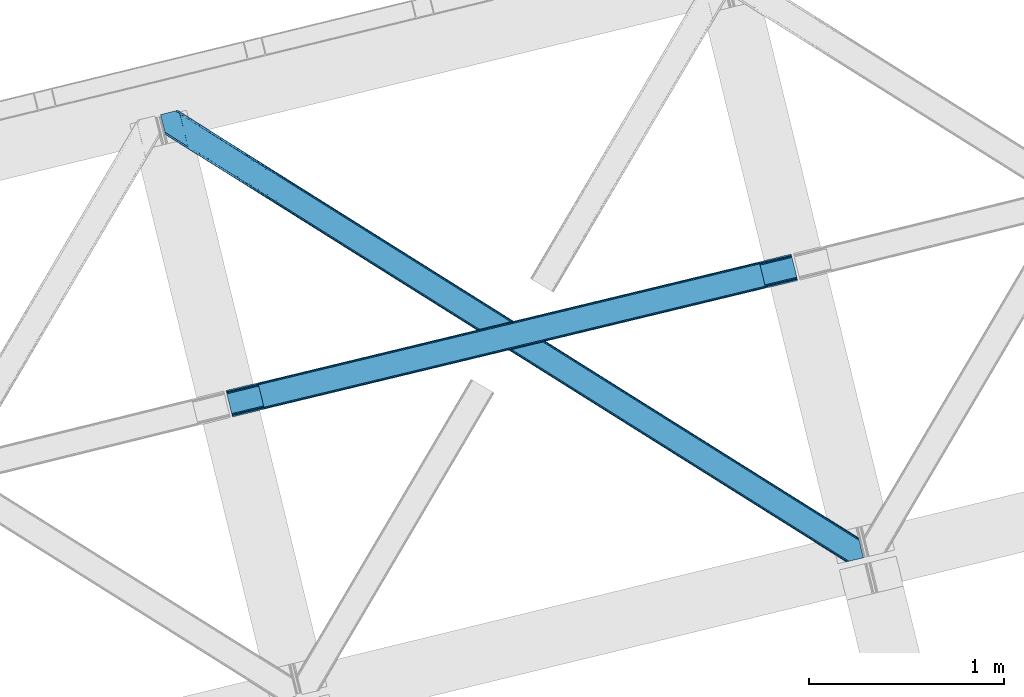
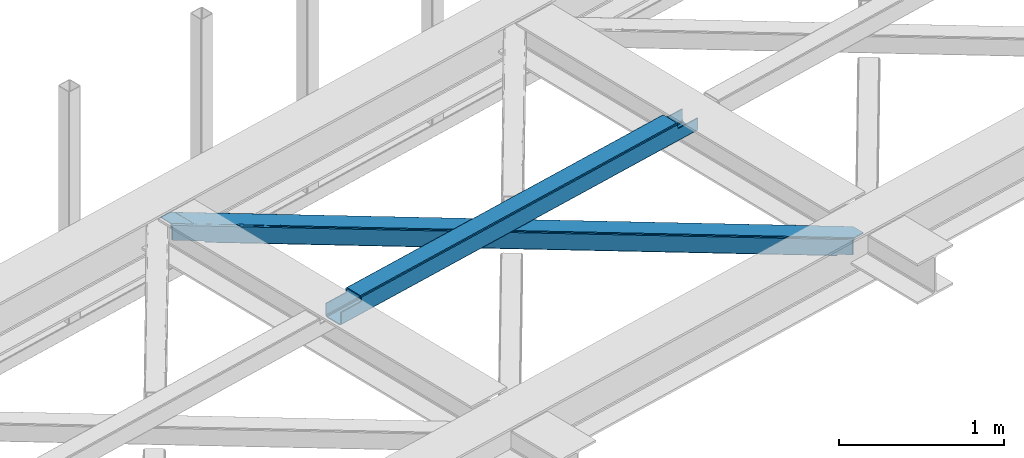
# One storey, part 20 of 66: 1 beam, 1 member.
"""IFC4 building model written with IfcOpenShell, lengths in millimetres."""

from ifc_helpers import new_model, entity, si_unit, converted_unit, derived_unit, direction, frame, origin, place, context, subcontext, project, spatial, triangles, polygons, material, type_object, element, save


model = new_model("IFC4")

# Units and contexts
model_context = context("Model", 3, precision=0.01, world=origin(), true_north=direction((6.12303176911189e-17, 1.0)))
plan_context = context("Plan", 3, precision=0.01, world=origin(), true_north=direction((6.12303176911189e-17, 1.0)))
body_context = subcontext(model_context, "Body", "Model", "MODEL_VIEW")
ifc_project = project(units=[si_unit("LENGTHUNIT", "METRE", prefix="MILLI"), si_unit("AREAUNIT", "SQUARE_METRE"), si_unit("VOLUMEUNIT", "CUBIC_METRE"), converted_unit("PLANEANGLEUNIT", "DEGREE", entity("IfcRatioMeasure", 0.0174532925199433), si_unit("PLANEANGLEUNIT", "RADIAN"), dimensions=[0, 0, 0, 0, 0, 0, 0]), si_unit("MASSUNIT", "GRAM", prefix="KILO"), derived_unit("MASSDENSITYUNIT", [(si_unit("MASSUNIT", "GRAM", prefix="KILO"), 1), (si_unit("LENGTHUNIT", "METRE"), -3)]), derived_unit("MOMENTOFINERTIAUNIT", [(si_unit("LENGTHUNIT", "METRE"), 4)]), si_unit("TIMEUNIT", "SECOND"), si_unit("FREQUENCYUNIT", "HERTZ"), si_unit("THERMODYNAMICTEMPERATUREUNIT", "DEGREE_CELSIUS"), derived_unit("THERMALTRANSMITTANCEUNIT", [(si_unit("MASSUNIT", "GRAM", prefix="KILO"), 1), (si_unit("THERMODYNAMICTEMPERATUREUNIT", "KELVIN"), -1), (si_unit("TIMEUNIT", "SECOND"), -3)]), derived_unit("VOLUMETRICFLOWRATEUNIT", [(si_unit("LENGTHUNIT", "METRE"), 3), (si_unit("TIMEUNIT", "SECOND"), -1)]), derived_unit("MASSFLOWRATEUNIT", [(si_unit("MASSUNIT", "GRAM", prefix="KILO"), 1), (si_unit("TIMEUNIT", "SECOND"), -1)]), derived_unit("ROTATIONALFREQUENCYUNIT", [(si_unit("TIMEUNIT", "SECOND"), -1)]), si_unit("ELECTRICCURRENTUNIT", "AMPERE"), si_unit("ELECTRICVOLTAGEUNIT", "VOLT"), si_unit("POWERUNIT", "WATT"), si_unit("FORCEUNIT", "NEWTON", prefix="KILO"), si_unit("ILLUMINANCEUNIT", "LUX"), si_unit("LUMINOUSFLUXUNIT", "LUMEN"), si_unit("LUMINOUSINTENSITYUNIT", "CANDELA"), derived_unit("USERDEFINED", [(si_unit("MASSUNIT", "GRAM", prefix="KILO"), -1), (si_unit("LENGTHUNIT", "METRE"), -2), (si_unit("TIMEUNIT", "SECOND"), 3), (si_unit("LUMINOUSFLUXUNIT", "LUMEN"), 1)]), derived_unit("LINEARVELOCITYUNIT", [(si_unit("LENGTHUNIT", "METRE"), 1), (si_unit("TIMEUNIT", "SECOND"), -1)]), si_unit("PRESSUREUNIT", "PASCAL"), derived_unit("USERDEFINED", [(si_unit("LENGTHUNIT", "METRE"), -2), (si_unit("MASSUNIT", "GRAM", prefix="KILO"), 1), (si_unit("TIMEUNIT", "SECOND"), -2)]), derived_unit("LINEARFORCEUNIT", [(si_unit("MASSUNIT", "GRAM", prefix="KILO"), 1), (si_unit("LENGTHUNIT", "METRE"), 1), (si_unit("TIMEUNIT", "SECOND"), -2), (si_unit("LENGTHUNIT", "METRE"), -1)]), derived_unit("PLANARFORCEUNIT", [(si_unit("MASSUNIT", "GRAM", prefix="KILO"), 1), (si_unit("LENGTHUNIT", "METRE"), 1), (si_unit("TIMEUNIT", "SECOND"), -2), (si_unit("LENGTHUNIT", "METRE"), -2)])], contexts=[model_context, plan_context])

# Site, building, storey
site_placement = place(None, origin())
site = spatial("IfcSite", under=ifc_project, at=site_placement, CompositionType="ELEMENT")
building_placement = place(site_placement, origin())
building = spatial("IfcBuilding", under=site, at=building_placement, CompositionType="ELEMENT")
storey_placement = place(building_placement, frame((0.0, 0.0, 19800.0)))
storey = spatial("IfcBuildingStorey", under=building, at=storey_placement, Name="06", CompositionType="ELEMENT", Elevation=19800.0)

# Beam
ifc_material = material(Name="Metal painted (White)")
beam_type = type_object("IfcBeamType", PredefinedType="BEAM")
beam_placement = place(storey_placement, frame((-57740.41, 5065.09, 3967.02)))
element("IfcBeam", 1, at=beam_placement, inside=storey, type_object=beam_type, material=ifc_material, ObjectType="Steel Beam", PredefinedType="BEAM", context=body_context, shape_type="Tessellation", body=[
    polygons([(195.780301044213, 46.4550586676728, 115.555285086674), (195.464822269693, 47.7492743886278, 122.252244531344), (2771.48985192152, 669.545541676776, 123.117713426555), (2771.80533069603, 668.25132595583, 116.42075398189), (194.566414729762, 51.4348889400316, 127.929650650905), (2770.59144438158, 673.231156228175, 128.795119546121), (193.221852828265, 56.9508009166206, 131.72316982947), (2769.24688248008, 678.747068204764, 132.588638724685), (191.635833926232, 63.4572627218112, 133.055273160435), (2767.66086357805, 685.253530009973, 133.920742055651), (170.084604912774, 151.868723803345, 133.055206290887), (2746.10963456458, 773.664991091508, 133.920675186102), (168.498586010742, 158.37518560857, 131.723093117664), (2744.52361566255, 780.171452896718, 132.588562012879), (167.154024109253, 163.891097585162, 127.929565595236), (2743.17905376107, 785.687364873307, 128.795034490451), (166.255616569314, 167.576712136562, 122.252153900486), (2742.28064622113, 789.372979424712, 123.117622795697), (165.940137794803, 168.870927857489, 115.55519249807), (2741.96516744662, 790.667195145647, 116.420661393281), (2740.30738059942, 797.468076767305, 101.477862601255), (2740.30738059942, 797.468076767303, 123.420656622786), (2740.62285937394, 796.173861046351, 130.117618025197), (2741.52126691387, 792.488246494948, 135.795029719952), (2742.86582881537, 786.97233451836, 139.58855724238), (2744.4518477174, 780.465872713163, 140.920670415603), (2769.31865042523, 678.452648388318, 140.920747572779), (2770.90466932728, 671.946186583087, 139.588644241809), (2772.24923122876, 666.430274606496, 135.795125063245), (2773.1476387687, 662.744660055096, 130.117718943684), (2773.46311754411, 661.450444330471, 123.420759499014), (2773.46311754321, 661.450444334177, 101.477862601255), (2771.80533069603, 668.251325955834, 101.477862601255), (2741.96516744661, 790.667195145648, 101.477862601255), (165.940137794803, 168.870927857486, 100.498086492688), (195.780301044213, 46.4550586676718, 100.498086492688), (197.438087891481, 39.6541770456987, 100.498086492688), (197.438087891403, 39.654177046016, 122.555290603803), (197.122609116892, 40.9483927669546, 129.252250048473), (196.224201576953, 44.6340073183542, 134.929656168034), (194.879639675456, 50.1499192949453, 138.723175346598), (193.293620773432, 56.6563811001544, 140.055278677564), (168.426818065593, 158.669605425, 140.055201520392), (166.840799163551, 165.17606723021, 138.723088347169), (165.496237262063, 170.6919792068, 134.929560824741), (164.597829722123, 174.377593758201, 129.252149129991), (164.282350947612, 175.671809479143, 122.555187727571), (164.282350947612, 175.671809479143, 100.498086492688), (2936.08768164363, 707.905503001759, 100.477862601264), (2936.08768164363, 707.90550300176, 25.4759431828493), (31.4979500966092, 6.80088162175, 24.5000861794941), (31.4979500966092, 6.80088162174783, 99.4980864926921), (194.80821612737, 46.2204185668087, 99.4980864926878), (1.65778684719908, 129.216750811564, 24.4999935908851), (2906.24751839422, 830.321372191575, 25.4758505942445), (2906.24751839422, 830.321372191573, 100.47786260126), (2742.93725236347, 790.901835246512, 100.47786260126), (1.65778684719908, 129.216750811561, 99.4980864926921), (2937.74546849234, 701.104621373772, 18.4759479533483), (2937.74546849731, 701.104621353716, 100.477862601264), (2774.43520246224, 661.685084426048, 100.47786260126), (33.1557369438083, 4.43975523012341e-11, 99.4980864926921), (33.1557369430373, 3.22152970966272e-09, 17.5000909499889), (2904.58973154703, 837.122253813229, 100.47786260126), (2904.58973154703, 837.122253813231, 18.4758450771161), (0.0, 136.01763243322, 17.4999880737609), (8.66293703438714e-12, 136.017632433219, 99.4980864926921), (163.310266030769, 175.437169378279, 99.4980864926878), (2772.77741561287, 668.485966056697, 100.47786260126), (2741.27946551628, 797.702716868168, 100.47786260126), (2906.56299716874, 829.027156470638, 18.7788911495745), (2907.46140470868, 825.341541919235, 13.1014850300135), (2908.80596661015, 819.825629942646, 9.30796585144909), (2910.39198551221, 813.319168137436, 7.9758625204836), (2931.94321452565, 724.907707055902, 7.97592939003242), (2933.52923342769, 718.401245250692, 9.30804256325522), (2934.87379532918, 712.885333274101, 13.1015700856834), (2935.77220286912, 709.199718722701, 18.7789817804291), (2937.4299897163, 702.398837101065, 11.7789865509282), (2936.53158217636, 706.084451652467, 6.10157485617812), (2935.18702027487, 711.600363629058, 2.30804733374998), (2933.60100137285, 718.106825434246, 0.975934160527186), (2908.73419866501, 820.120049759092, 0.975857003355134), (2907.14817976297, 826.626511564317, 2.30796033432063), (2905.80361786149, 832.142423540906, 6.10147951288502), (2904.90521032155, 835.828038092307, 11.778885632446), (196.466002974552, 39.4195369451518, 99.4980864926921), (164.968052877951, 168.636287756623, 99.4980864926921), (27.3534829786288, 23.8030856758895, 7.00007238667729), (28.9395018806531, 17.2966238706989, 8.33218555989575), (30.2840637821498, 11.7807118941088, 12.1257130823239), (31.1824713220894, 8.09509734270817, 17.8031247770739), (1.97326562170153, 127.922535090635, 17.8030341462107), (2.87167316164112, 124.236920539239, 12.125628026654), (4.21623506313788, 118.721008562646, 8.33210884808963), (5.80225396517078, 112.214546757422, 7.00000551712413), (0.315478774511121, 134.723416712281, 10.8030286290822), (1.2138863144507, 131.037802160879, 5.12562250952556), (2.55844821594746, 125.52189018429, 1.33210333096549), (4.14446711798037, 119.01542837908, 0.0), (29.0112698258193, 17.0022040542358, 7.71571720520115e-05), (30.5972887278522, 10.4957422490247, 1.33219033039485), (31.9418506293316, 4.97983027243569, 5.12571785281865), (32.8402581692712, 1.29421572103505, 10.8031295475687)], [[[1, 2, 3, 4]], [[2, 5, 6, 3]], [[5, 7, 8, 6]], [[7, 9, 10, 8]], [[11, 12, 10, 9]], [[11, 13, 14, 12]], [[13, 15, 16, 14]], [[15, 17, 18, 16]], [[17, 19, 20, 18]], [[21, 22, 23, 24, 25, 26, 27, 28, 29, 30, 31, 32, 33, 4, 3, 6, 8, 10, 12, 14, 16, 18, 20, 34]], [[35, 19, 17, 15, 13, 11, 9, 7, 5, 2, 1, 36, 37, 38, 39, 40, 41, 42, 43, 44, 45, 46, 47, 48]], [[42, 41, 28, 27]], [[41, 40, 29, 28]], [[40, 39, 30, 29]], [[39, 38, 31, 30]], [[27, 26, 43, 42]], [[47, 46, 23, 22]], [[46, 45, 24, 23]], [[45, 44, 25, 24]], [[44, 43, 26, 25]], [[33, 49, 50, 51, 52, 53, 1, 4]], [[54, 55, 56, 57, 20, 19, 35, 58]], [[59, 60, 61, 31, 38, 37, 62, 63]], [[64, 65, 66, 67, 68, 47, 22, 21]], [[61, 60, 49, 69]], [[64, 70, 57, 56]], [[65, 64, 56, 55, 71, 72, 73, 74, 75, 76, 77, 78, 50, 49, 60, 59, 79, 80, 81, 82, 83, 84, 85, 86]], [[87, 53, 52, 62]], [[67, 58, 88, 68]], [[89, 90, 76, 75]], [[90, 91, 77, 76]], [[91, 92, 78, 77]], [[92, 51, 50, 78]], [[54, 93, 71, 55]], [[93, 94, 72, 71]], [[94, 95, 73, 72]], [[95, 96, 74, 73]], [[89, 75, 74, 96]], [[66, 97, 98, 99, 100, 101, 102, 103, 104, 63, 62, 52, 51, 92, 91, 90, 89, 96, 95, 94, 93, 54, 58, 67]], [[63, 104, 79, 59]], [[104, 103, 80, 79]], [[103, 102, 81, 80]], [[102, 101, 82, 81]], [[100, 99, 84, 83]], [[99, 98, 85, 84]], [[98, 97, 86, 85]], [[97, 66, 65, 86]], [[83, 82, 101, 100]]], closed=False),
])

# Member
member_type = type_object("IfcMemberType", PredefinedType="BRACE")
member_placement = place(storey_placement, frame((-58076.85, 4319.82, 3824.0)))
element("IfcMember", 2, at=member_placement, inside=storey, type_object=member_type, ObjectType="Steel Horizontal Brace", PredefinedType="BRACE", context=body_context, shape_type="Tessellation", body=[
    triangles([(207.717553710943, 2101.81647491455, 0.0), (172.040661621097, 2248.17905273437, 0.0), (3404.48986816406, 219.293300628662, 0.0), (3440.17141113282, 72.9304321289064, 0.0), (202.587634277348, 2097.1307144165, 1.33247680664135), (208.508203125006, 2098.57481231689, 0.155804443358647), (3442.44569091797, 63.5952461242678, 1.33247680664135), (3445.6640991211, 50.3934356689451, 10.8039916992202), (3446.115234375, 48.5365722656252, 17.5012573242202), (187.951318359381, 2093.56290893555, 17.5012573242202), (189.755859375, 2094.00299835205, 10.8039916992202), (3444.37580566407, 55.6814849853517, 5.12526855468968), (194.895080566406, 2095.25582885742, 5.12526855468968), (3405.08983154297, 238.005821228027, 10.8039916992202), (3400.22036132813, 236.818393707275, 5.32758178711083), (167.83626708985, 2265.42799987793, 5.12526855468968), (166.547973632813, 2270.71604919434, 10.8039916992202), (3400.29942626954, 236.497483062744, 5.1694519042976), (3402.21558837891, 228.628195953369, 1.33247680664135), (169.766381835943, 2257.51394805908, 1.33247680664135), (3406.8943725586, 238.445619964599, 17.5012573242202), (166.096838378908, 2272.57291259766, 17.5012573242202), (3401.19239501953, 237.055007171631, 18.5197998046897), (3406.8943725586, 238.445619964599, 18.5197998046897), (3400.50406494141, 236.887575531006, 18.2267944335945), (3400.82032470703, 236.96460571289, 18.4453857421868), (3400.29477539063, 236.836415863037, 17.9035583496116), (3400.22036132813, 236.818393707275, 17.5198608398459), (3402.04350585938, 231.951539611817, 18.4453857421868), (3401.8388671875, 231.936424255371, 18.1454040527351), (3401.62027587891, 231.920436859131, 17.8198425292976), (3401.6109741211, 231.919564819336, 17.8058898925774), (3401.41563720704, 231.905321502685, 17.5198608398459), (3402.49929199219, 231.698357391358, 18.5197998046897), (3586.9019897461, 125.462400054932, 18.5197998046897), (3589.63670654297, 114.236631774902, 18.5197998046897), (204.378222656254, 2097.56789703369, 12.1248413085959), (208.508203125006, 2098.57481231689, 9.69243164062573), (199.652929687501, 2096.4150604248, 17.9802978515618), (198.425097656254, 2096.11566009521, 19.5011352539077), (187.951318359381, 2093.56290893555, 19.5011352539077), (25.3100830078183, 2195.64679412842, 19.5011352539077), (22.6823364257871, 2206.42171783447, 19.5011352539077), (3437.79016113281, 82.6879760742186, 6.99957275390625), (3404.59683837891, 218.870942687989, 8.3320495605476), (3402.66672363281, 226.784703826905, 12.1248413085959), (3406.87111816407, 209.53575668335, 6.99957275390625), (3443.24564208985, 60.3184112548824, 17.5198608398459), (3441.99455566407, 65.4390289306639, 12.1248413085959), (3446.115234375, 48.5365722656252, 17.5198608398459), (3440.06444091797, 73.3527900695799, 8.3320495605476), (1232.85963134766, 1574.07833862305, 6.99957275390625), (640.584155273442, 1945.82774047852, 6.99957275390625), (602.800415039063, 1862.1026184082, 6.99957275390625), (1195.07589111329, 1490.35496063232, 6.99957275390625), (1825.13510742188, 1202.32951812744, 6.99957275390625), (1787.3467163086, 1118.60788421631, 6.99957275390625), (205.340954589847, 2111.57401885986, 6.99957275390625), (174.421911621095, 2238.42150878906, 6.99957275390625), (2971.89301757813, 375.112859344483, 6.99957275390625), (3009.69071044922, 458.831295776367, 6.99957275390625), (2379.62219238281, 746.86022644043, 6.99957275390625), (2417.415234375, 830.580697631836, 6.99957275390625), (168.836206054693, 2261.33697052002, 18.501196289064), (166.096838378908, 2272.57291259766, 18.501196289064), (168.971081542972, 2260.78584136963, 17.8803039550803), (170.217517089848, 2255.67045593262, 12.1248413085959), (172.142980957033, 2247.75640411377, 8.3320495605476), (207.559423828126, 2102.47631835938, 8.8831787109375), (3444.59439697266, 58.9995964050295, 18.5197998046897), (3447.32911376953, 47.7738281250004, 18.5197998046897), (3447.04541015625, 47.9543403625485, 18.2849304199226), (3444.26883544922, 59.3176002502441, 18.2802795410171), (3446.72449951172, 48.1552001953123, 18.0198303222678), (3443.92001953125, 59.6591491699219, 18.0198303222678), (3446.40358886719, 48.356350708008, 17.757055664064), (3443.62701416016, 59.9422714233397, 17.8058898925774), (3443.57120361328, 60.0006980895996, 17.7617065429695), (3534.35635986328, 2.65972137451172, 18.5197998046897), (3523.44539794922, 0.0, 18.5197998046897), (2962.59125976563, 360.290798950195, 24.5008300781265), (2963.29819335938, 361.419218444824, 17.8035644531265), (3532.92854003907, 2.31206817626935, 24.5008300781265), (2965.31667480469, 364.632103729248, 12.1248413085959), (596.224072265628, 1851.62186279297, 12.1248413085959), (599.242492675781, 1856.43029022217, 8.3320495605476), (594.205590820318, 1848.40868682861, 17.8035644531265), (593.498657226563, 1847.28026733398, 24.5008300781265), (22.9288330078125, 2205.40433807373, 24.5008300781265), (2968.33509521485, 369.440821838379, 8.3320495605476), (2370.32043457031, 732.038456726074, 24.5008300781265), (2371.02736816407, 733.16629486084, 17.8035644531265), (1778.75189208984, 1104.91395263672, 17.8035644531265), (1778.0449584961, 1103.78553314209, 24.5008300781265), (1186.48106689454, 1476.66102905273, 17.8035644531265), (1185.77413330079, 1475.53319091797, 24.5008300781265), (2373.04119873047, 736.379470825195, 12.1248413085959), (1780.77037353516, 1108.12712860107, 12.1248413085959), (1188.49489746094, 1479.87420501709, 12.1248413085959), (2376.05961914063, 741.188479614258, 8.3320495605476), (1783.78879394531, 1112.93555603027, 8.3320495605476), (1191.5133178711, 1484.68263244629, 8.3320495605476), (2965.14924316407, 350.421343231201, 122.499499511719), (2371.32037353516, 723.143650817871, 122.499499511719), (3523.44539794922, 0.0, 122.499499511719), (1777.49615478516, 1095.86624908447, 122.499499511719), (1183.66728515625, 1468.58884735107, 122.499499511719), (589.843066406254, 1841.31144561768, 122.499499511719), (25.3100830078183, 2195.64679412842, 122.499499511719), (3532.92854003907, 2.31206817626935, 115.499926757813), (22.9288330078125, 2205.40433807373, 115.499926757813), (3534.73308105469, 2.75186691284216, 122.197192382813), (22.4776977539077, 2207.26120147705, 122.197192382813), (3539.8723022461, 4.00469741821325, 127.873590087893), (21.1894042968779, 2212.54925079346, 127.873590087893), (3547.56485595703, 5.87958297729529, 131.668707275392), (19.2592895507842, 2220.4633026123, 131.668707275392), (3556.63872070313, 8.09165725708044, 133.001184082033), (16.9850097656308, 2229.79819793701, 133.001184082033), (3525.24993896484, 0.440089416503724, 129.196765136719), (3530.38916015625, 1.69291992187482, 134.87548828125), (3547.15557861328, 5.77958908081018, 140.00075683594), (3612.21207275391, 21.6376327514645, 140.00075683594), (3612.21207275391, 21.6376327514645, 133.001184082033), (3538.08171386719, 3.56780548095685, 138.668280029298), (168.515295410158, 2261.63113861084, 18.7407165527366), (165.808483886722, 2272.75313415527, 18.7360656738274), (168.171130371098, 2261.94914245605, 19.0011657714858), (165.487573242193, 2272.95428466797, 19.0011657714858), (167.826965332031, 2262.26714630127, 19.2592895507805), (165.166662597658, 2273.1548538208, 19.2639404296897), (167.506054687503, 2262.56131439209, 19.5011352539077), (164.878308105472, 2273.33565673828, 19.5011352539077), (78.2928955078169, 2318.55673370361, 19.5011352539077), (88.7666748046904, 2321.10948486328, 19.5011352539077), (649.178979492193, 1959.52167205811, 17.8035644531265), (3018.28553466797, 472.525227355957, 17.8035644531265), (3016.26705322266, 469.312342071533, 12.1248413085959), (3018.99246826172, 473.653646850586, 24.5008300781265), (3589.2832397461, 115.704856109619, 24.5008300781265), (649.890563964844, 1960.65009155273, 24.5008300781265), (79.2835327148496, 2318.79799804688, 24.5008300781265), (3013.2486328125, 464.503623962402, 8.3320495605476), (644.146728515625, 1951.49948730469, 8.3320495605476), (647.165148925786, 1956.30849609375, 12.1248413085959), (2420.97315673828, 836.252444458008, 8.3320495605476), (1828.69768066407, 1208.00184631348, 8.3320495605476), (1236.42220458985, 1579.75066680908, 8.3320495605476), (2423.99157714844, 841.06145324707, 12.1248413085959), (1831.71610107422, 1212.81027374268, 12.1248413085959), (1239.440625, 1584.55967559814, 12.1248413085959), (2426.01005859375, 844.274629211426, 17.8035644531265), (1833.73458251954, 1216.02344970703, 17.8035644531265), (1241.45445556641, 1587.77227020264, 17.8035644531265), (2426.7169921875, 845.402467346192, 24.5008300781265), (1834.44151611329, 1217.15186920166, 24.5008300781265), (1242.16604003907, 1588.90068969727, 24.5008300781265), (1247.70523681641, 1593.6864440918, 122.499499511719), (653.815905761723, 1966.45090026855, 122.499499511719), (1841.59921875, 1220.9225692749, 122.499499511719), (3586.9019897461, 125.462400054932, 122.499499511719), (2435.4932006836, 848.158694458008, 122.499499511719), (3029.38718261719, 475.394528961182, 122.499499511719), (88.7666748046904, 2321.10948486328, 122.499499511719), (3591.02266845704, 108.560234069824, 127.873590087893), (3588.64606933594, 118.317487335205, 134.87548828125), (3590.57153320313, 110.403726196289, 138.668280029298), (3592.95278320313, 100.646182250976, 131.668707275392), (3595.22706298828, 91.3109962463377, 133.001184082033), (3592.85046386719, 101.068540191651, 140.00075683594), (3589.734375, 113.847992706299, 122.197192382813), (3587.353125, 123.605536651611, 129.196765136719), (3589.2832397461, 115.704856109619, 115.499926757813), (55.5733520507856, 2313.01811828613, 133.001184082033), (0.0, 2299.47185211182, 133.001184082033), (79.2835327148496, 2318.79799804688, 115.499926757813), (64.647216796875, 2315.23019256592, 131.668707275392), (72.3397705078169, 2317.105078125, 127.873590087893), (77.4789916992231, 2318.35790863037, 122.197192382813), (76.0651245117188, 2318.01316223145, 138.000878906252), (81.8229125976577, 2319.41656494141, 134.87548828125), (86.962133789064, 2320.66939544678, 129.196765136719), (0.0, 2299.47185211182, 138.000878906252), (24.8542968750044, 2197.50365753174, 129.196765136719), (23.5660034179746, 2202.79170684814, 134.87548828125), (22.1242309570371, 2208.71692657471, 138.000878906252), (98.1940063476577, 2304.12389373779, 138.000878906252), (139.391491699222, 2135.11211700439, 138.000878906252), (599.144824218754, 1856.13379669189, 140.00075683594), (139.828674316406, 2137.54568939209, 139.000817871096), (140.051916503908, 2136.3818069458, 138.668280029298), (137.847399902348, 2145.67368164062, 140.00075683594), (592.563830566411, 1845.65304107666, 134.87548828125), (139.805419921875, 2135.0249130249, 138.075292968751), (595.582250976564, 1850.46146850586, 138.668280029298), (139.921691894531, 2135.65917663574, 138.352020263672), (140.037963867188, 2136.29576568604, 138.631072998047), (2974.45100097657, 365.243403625488, 140.00075683594), (2970.89307861328, 359.571075439453, 138.668280029298), (2967.87465820313, 354.762357330323, 134.87548828125), (2965.85617675781, 351.549472045898, 129.196765136719), (590.550000000003, 1842.4398651123, 129.196765136719), (2372.03195800781, 724.2720703125, 129.196765136719), (1778.20308837891, 1096.9946685791, 129.196765136719), (1184.37421875, 1469.7172668457, 129.196765136719), (2374.04578857422, 727.485246276856, 134.87548828125), (1780.22156982422, 1100.20784454346, 134.87548828125), (1186.39270019531, 1472.93044281006, 134.87548828125), (2377.06420898438, 732.293673706055, 138.668280029298), (1783.23999023438, 1105.01627197266, 138.668280029298), (1189.41112060547, 1477.73887023926, 138.668280029298), (2380.62678222657, 737.966001892089, 140.00075683594), (1786.79791259766, 1110.68860015869, 140.00075683594), (1192.97369384766, 1483.41119842529, 140.00075683594), (651.090490722658, 1962.10930480957, 134.87548828125), (98.7056030273452, 2303.62683105469, 138.075292968751), (99.1985961914106, 2302.47515716553, 138.384576416018), (648.072070312504, 1957.30087738037, 138.668280029298), (99.5985717773438, 2301.53800506592, 138.633398437501), (644.509497070314, 1951.62854919434, 140.00075683594), (100.184582519534, 2300.16425170898, 139.000817871096), (102.1658569336, 2292.03684082031, 140.00075683594), (3028.68024902344, 474.266400146485, 129.196765136719), (3026.66176757813, 471.053224182129, 134.87548828125), (3023.64334716797, 466.244506072998, 138.668280029298), (3020.08077392579, 460.572177886963, 140.00075683594), (653.104321289065, 1965.32248077393, 129.196765136719), (2429.74936523438, 839.008671569824, 138.668280029298), (2426.1914428711, 833.336343383789, 140.00075683594), (1835.85538330078, 1211.77254638672, 138.668280029298), (1832.2974609375, 1206.10021820068, 140.00075683594), (1241.9660522461, 1584.53642120361, 138.668280029298), (1238.40347900391, 1578.86409301758, 140.00075683594), (2432.76778564454, 843.817098999023, 134.87548828125), (1838.87380371094, 1216.58155517578, 134.87548828125), (1244.98447265625, 1589.34542999268, 134.87548828125), (2434.78626708985, 847.030274963379, 129.196765136719), (1840.89228515625, 1219.79414978027, 129.196765136719), (1246.99830322266, 1592.55802459717, 129.196765136719)], [[1, 2, 3], [3, 4, 1], [5, 6, 4], [4, 7, 5], [8, 9, 10], [10, 11, 8], [12, 8, 11], [11, 13, 12], [7, 12, 13], [13, 5, 7], [6, 1, 4], [14, 15, 16], [16, 17, 14], [18, 19, 20], [19, 3, 2], [2, 20, 19], [20, 16, 18], [15, 18, 16], [21, 14, 17], [17, 22, 21], [23, 21, 24], [25, 23, 26], [23, 25, 27], [23, 27, 28], [21, 23, 28], [28, 15, 14], [14, 21, 28], [26, 29, 30], [25, 30, 31], [27, 32, 33], [27, 31, 32], [33, 28, 27], [31, 27, 25], [30, 25, 26], [23, 34, 29], [29, 26, 23], [34, 24, 35], [24, 34, 23], [35, 36, 34], [37, 38, 5], [37, 5, 13], [13, 11, 39], [38, 6, 5], [39, 37, 13], [11, 10, 40], [41, 40, 10], [11, 40, 39], [42, 43, 40], [40, 41, 42], [3, 44, 4], [45, 19, 46], [33, 15, 28], [18, 33, 46], [33, 18, 15], [3, 19, 45], [46, 19, 18], [3, 47, 44], [45, 47, 3], [8, 48, 9], [48, 12, 49], [12, 48, 8], [50, 9, 48], [49, 7, 51], [51, 4, 44], [4, 51, 7], [49, 12, 7], [52, 53, 54], [54, 55, 52], [55, 56, 52], [56, 55, 57], [53, 58, 54], [53, 59, 58], [60, 61, 62], [61, 60, 47], [44, 47, 60], [63, 62, 61], [57, 63, 56], [62, 63, 57], [17, 22, 64], [22, 65, 64], [66, 17, 64], [66, 16, 17], [67, 16, 66], [20, 67, 68], [67, 20, 16], [2, 20, 68], [68, 59, 2], [69, 38, 6], [69, 1, 58], [1, 59, 58], [59, 1, 2], [69, 6, 1], [70, 71, 72], [72, 73, 70], [73, 72, 74], [74, 75, 73], [75, 76, 77], [75, 74, 76], [76, 78, 77], [78, 76, 50], [50, 48, 78], [71, 70, 79], [79, 80, 71], [81, 70, 73], [73, 82, 81], [73, 75, 82], [75, 77, 82], [83, 79, 70], [70, 81, 83], [82, 77, 78], [78, 84, 82], [78, 48, 84], [48, 49, 84], [54, 58, 69], [85, 86, 38], [86, 69, 38], [87, 85, 37], [88, 87, 39], [39, 40, 88], [88, 40, 89], [43, 89, 40], [37, 39, 87], [38, 37, 85], [69, 86, 54], [51, 44, 90], [60, 90, 44], [49, 51, 84], [90, 84, 51], [81, 82, 91], [92, 91, 82], [91, 92, 93], [93, 94, 91], [94, 93, 95], [95, 96, 94], [96, 95, 87], [87, 88, 96], [82, 84, 97], [97, 92, 82], [92, 97, 98], [98, 93, 92], [93, 98, 99], [99, 95, 93], [95, 99, 85], [85, 87, 95], [84, 90, 100], [100, 97, 84], [97, 100, 101], [101, 98, 97], [98, 101, 102], [102, 99, 98], [99, 102, 86], [86, 85, 99], [90, 60, 100], [62, 100, 60], [100, 62, 101], [57, 101, 62], [101, 57, 55], [55, 102, 101], [102, 55, 54], [54, 86, 102], [9, 103, 104], [71, 105, 72], [71, 80, 105], [105, 74, 72], [50, 105, 103], [50, 76, 105], [76, 74, 105], [9, 50, 103], [106, 10, 9], [10, 107, 108], [109, 41, 108], [106, 107, 10], [106, 9, 104], [10, 108, 41], [42, 41, 109], [81, 110, 83], [110, 81, 91], [110, 94, 111], [94, 110, 91], [88, 89, 111], [96, 111, 94], [111, 96, 88], [112, 110, 111], [111, 113, 112], [114, 112, 113], [113, 115, 114], [116, 114, 115], [115, 117, 116], [118, 116, 117], [117, 119, 118], [112, 120, 121], [118, 122, 123], [123, 124, 118], [118, 116, 122], [116, 125, 122], [114, 125, 116], [121, 125, 114], [112, 105, 120], [110, 105, 112], [121, 114, 112], [80, 83, 79], [110, 80, 105], [83, 80, 110], [65, 64, 126], [126, 127, 65], [127, 126, 128], [128, 129, 127], [129, 128, 130], [130, 131, 129], [131, 130, 132], [132, 133, 131], [134, 135, 133], [133, 132, 134], [136, 66, 67], [137, 138, 33], [138, 46, 33], [139, 29, 34], [34, 140, 139], [34, 36, 140], [139, 137, 32], [32, 31, 139], [30, 29, 139], [139, 31, 30], [141, 130, 128], [141, 132, 130], [128, 136, 141], [64, 136, 126], [128, 126, 136], [64, 66, 136], [132, 141, 142], [142, 134, 132], [33, 32, 137], [45, 46, 143], [138, 143, 46], [47, 45, 61], [143, 61, 45], [53, 144, 59], [68, 59, 144], [144, 145, 68], [67, 68, 145], [67, 145, 136], [61, 143, 146], [146, 63, 61], [63, 146, 147], [147, 56, 63], [56, 147, 148], [148, 52, 56], [52, 148, 144], [144, 53, 52], [143, 138, 146], [149, 146, 138], [146, 149, 147], [150, 147, 149], [147, 150, 148], [151, 148, 150], [148, 151, 144], [145, 144, 151], [138, 137, 152], [152, 149, 138], [149, 152, 153], [153, 150, 149], [150, 153, 154], [154, 151, 150], [151, 154, 136], [136, 145, 151], [137, 139, 152], [155, 152, 139], [152, 155, 153], [156, 153, 155], [153, 156, 154], [157, 154, 156], [154, 157, 136], [141, 136, 157], [158, 22, 159], [22, 158, 160], [161, 35, 24], [21, 160, 162], [21, 163, 24], [160, 21, 22], [24, 163, 161], [162, 163, 21], [164, 159, 65], [164, 65, 127], [22, 65, 159], [129, 164, 127], [164, 129, 131], [131, 133, 164], [135, 164, 133], [165, 166, 167], [165, 167, 168], [169, 168, 170], [171, 166, 165], [124, 169, 123], [170, 123, 169], [168, 167, 170], [172, 166, 171], [35, 161, 173], [140, 35, 173], [35, 140, 36], [172, 171, 161], [171, 173, 161], [119, 174, 169], [174, 119, 175], [169, 118, 119], [124, 118, 169], [156, 173, 176], [173, 155, 139], [156, 155, 173], [139, 140, 173], [157, 176, 141], [176, 157, 156], [142, 141, 176], [168, 169, 174], [174, 177, 168], [165, 168, 177], [177, 178, 165], [171, 165, 178], [178, 179, 171], [173, 171, 179], [179, 176, 173], [177, 174, 180], [181, 178, 180], [177, 180, 178], [179, 181, 182], [174, 183, 180], [174, 175, 183], [179, 178, 181], [164, 176, 179], [176, 164, 135], [142, 135, 134], [135, 142, 176], [164, 179, 182], [111, 42, 109], [184, 113, 109], [113, 184, 185], [113, 111, 109], [89, 42, 111], [43, 42, 89], [115, 113, 185], [186, 119, 117], [119, 186, 183], [183, 175, 119], [117, 115, 186], [186, 115, 185], [180, 186, 187], [180, 183, 186], [188, 187, 186], [189, 190, 191], [189, 192, 190], [193, 194, 188], [188, 185, 193], [188, 186, 185], [195, 196, 194], [195, 191, 196], [194, 193, 195], [197, 195, 189], [125, 122, 198], [198, 199, 125], [121, 125, 199], [199, 200, 121], [120, 121, 200], [200, 201, 120], [105, 120, 201], [201, 103, 105], [108, 202, 109], [184, 109, 202], [202, 193, 184], [185, 184, 193], [103, 201, 104], [203, 104, 201], [104, 203, 204], [204, 106, 104], [106, 204, 205], [205, 107, 106], [107, 205, 108], [202, 108, 205], [201, 200, 203], [206, 203, 200], [203, 206, 204], [207, 204, 206], [204, 207, 208], [208, 205, 204], [205, 208, 193], [193, 202, 205], [200, 199, 209], [209, 206, 200], [206, 209, 210], [210, 207, 206], [207, 210, 208], [211, 208, 210], [208, 211, 193], [195, 193, 211], [199, 198, 209], [212, 209, 198], [209, 212, 213], [213, 210, 209], [210, 213, 214], [214, 211, 210], [211, 214, 189], [189, 195, 211], [215, 216, 217], [217, 218, 215], [217, 219, 218], [187, 215, 181], [181, 180, 187], [219, 220, 218], [219, 221, 220], [221, 222, 220], [172, 161, 223], [163, 223, 161], [166, 172, 224], [223, 224, 172], [167, 166, 225], [224, 225, 166], [170, 167, 226], [225, 226, 167], [215, 227, 182], [182, 181, 215], [227, 159, 164], [164, 182, 227], [226, 225, 228], [228, 229, 226], [229, 228, 230], [230, 231, 229], [231, 230, 232], [232, 233, 231], [233, 232, 218], [218, 220, 233], [225, 224, 234], [234, 228, 225], [228, 234, 235], [235, 230, 228], [230, 235, 236], [236, 232, 230], [232, 236, 215], [215, 218, 232], [224, 223, 234], [237, 234, 223], [234, 237, 235], [238, 235, 237], [235, 238, 236], [239, 236, 238], [236, 239, 215], [227, 215, 239], [223, 163, 162], [162, 237, 223], [237, 162, 160], [160, 238, 237], [238, 160, 158], [158, 239, 238], [239, 158, 159], [159, 227, 239], [214, 233, 189], [233, 214, 231], [213, 231, 214], [231, 213, 229], [222, 192, 220], [189, 220, 192], [220, 189, 233], [170, 226, 198], [198, 122, 170], [123, 170, 122], [226, 212, 198], [212, 229, 213], [226, 229, 212], [197, 190, 221], [221, 219, 197], [219, 217, 194], [217, 216, 194], [222, 221, 192], [190, 192, 221]]),
])

save(model, "model.ifc")
